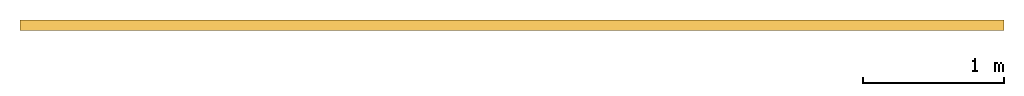
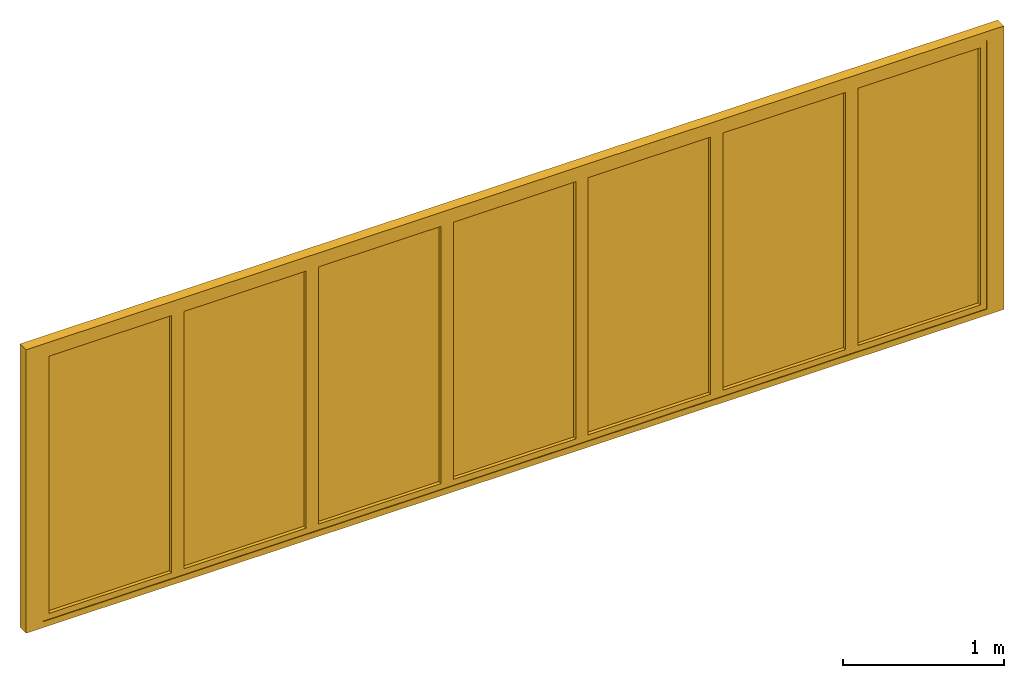
# One storey: 1 door.
"""IFC2X3 building model written with IfcOpenShell, lengths in millimetres."""

from ifc_helpers import new_model, entity, si_unit, converted_unit, direction, frame, frame_2d, origin, origin_2d_with_axis, place, context, subcontext, project, spatial, polyline, rectangle, outline, extrude, source, transform, mapped, material, material_list, type_object, type_shapes, element, save


model = new_model("IFC2X3")

# Units and contexts
model_context = context("Model", 3, precision=1e-06, world=origin(), true_north=direction((2.0, -1.71512652170913e-15, 1.0)))
context_of_model = context(None, 3, precision=1e-06, world=origin(), true_north=direction((2.0, -1.71512652170913e-15, 1.0)))
body_context = subcontext(model_context, "Body", "Model", "MODEL_VIEW")
ifc_project = project(units=[si_unit("LENGTHUNIT", "METRE", prefix="MILLI"), si_unit("AREAUNIT", "SQUARE_METRE", prefix="MILLI"), si_unit("VOLUMEUNIT", "CUBIC_METRE", prefix="MILLI"), converted_unit("PLANEANGLEUNIT", "DEGREE", entity("IfcRatioMeasure", 0.0174532925199433), si_unit("PLANEANGLEUNIT", "RADIAN"), dimensions=[0, 0, 0, 0, 0, 0, 0]), si_unit("TIMEUNIT", "SECOND")], contexts=[model_context, context_of_model])

# Site, building, storey
site_placement = place(None, origin())
site = spatial("IfcSite", under=ifc_project, at=site_placement, CompositionType="ELEMENT")
building_placement = place(site_placement, origin())
building = spatial("IfcBuilding", under=site, at=building_placement, CompositionType="ELEMENT")
storey_placement = place(building_placement, origin())
storey = spatial("IfcBuildingStorey", under=building, at=storey_placement, Name="Ground Floor", CompositionType="ELEMENT", Elevation=0.0)

# Door
ifc_material_1 = material(Name="Glass-Blue")
ifc_material_2 = material(Name="Mtl-Aluminium")
ifc_material_list = material_list([ifc_material_1, ifc_material_2])
door_style = type_object("IfcDoorStyle", ConstructionType="NOTDEFINED", OperationType="NOTDEFINED", ParameterTakesPrecedence=False, Sizeable=False)
shared_shape = source(origin(), body_context, "Body", "SweptSolid", [
    extrude(rectangle(XDim=876.399999999999, YDim=18.0, at=frame_2d((-5.40012479177676e-13, -1.68753899743024e-14), x_axis=(1.0, 0.0))), frame((6845.3148, 265.0, 44.3), z_axis=(0.0, 0.0, 1.0), x_axis=(-1.0, 0.0, 0.0)), (0.0, 0.0, 1.0), 1946.4),
    extrude(outline(polyline([(-482.500000000001, -1017.5), (482.5, -1017.5), (482.5, 1017.5), (-482.500000000001, 1017.5), (-482.500000000001, -1017.5)]), holes=[polyline([(438.199999999999, 973.2), (438.199999999999, -973.2), (-438.2, -973.2), (-438.2, 973.2), (438.199999999999, 973.2)])]), frame((6845.3148, 230.0, 1017.5), z_axis=(0.0, 1.0, 0.0), x_axis=(-1.0, 0.0, 0.0)), (0.0, 0.0, 1.0), 70.0),
    extrude(rectangle(XDim=876.4, YDim=18.0, at=frame_2d((0.0, -1.68753899743024e-14), x_axis=(1.0, 0.0))), frame((5880.3148, 265.0, 44.3), z_axis=(0.0, 0.0, 1.0), x_axis=(-1.0, 0.0, 0.0)), (0.0, 0.0, 1.0), 1946.4),
    extrude(outline(polyline([(-482.5, -1017.5), (482.500000000001, -1017.5), (482.500000000001, 1017.5), (-482.5, 1017.5), (-482.5, -1017.5)]), holes=[polyline([(438.2, 973.2), (438.2, -973.2), (-438.2, -973.2), (-438.2, 973.2), (438.2, 973.2)])]), frame((5880.3148, 230.0, 1017.5), z_axis=(0.0, 1.0, 0.0), x_axis=(-1.0, 0.0, 0.0)), (0.0, 0.0, 1.0), 70.0),
    extrude(rectangle(XDim=876.399999999999, YDim=18.0, at=frame_2d((-2.55795384873636e-13, -1.68753899743024e-14), x_axis=(1.0, 0.0))), frame((4915.3148, 265.0, 44.3), z_axis=(0.0, 0.0, 1.0), x_axis=(-1.0, 0.0, 0.0)), (0.0, 0.0, 1.0), 1946.4),
    extrude(outline(polyline([(-482.5, -1017.5), (482.5, -1017.5), (482.5, 1017.5), (-482.5, 1017.5), (-482.5, -1017.5)]), holes=[polyline([(438.199999999999, 973.2), (438.199999999999, -973.2), (-438.2, -973.2), (-438.2, 973.2), (438.199999999999, 973.2)])]), frame((4915.3148, 230.0, 1017.5), z_axis=(0.0, 1.0, 0.0), x_axis=(-1.0, 0.0, 0.0)), (0.0, 0.0, 1.0), 70.0),
    extrude(rectangle(XDim=876.4, YDim=18.0, at=frame_2d((0.0, -1.68753899743024e-14), x_axis=(1.0, 0.0))), frame((3950.3148, 265.0, 44.3), z_axis=(0.0, 0.0, 1.0), x_axis=(-1.0, 0.0, 0.0)), (0.0, 0.0, 1.0), 1946.4),
    extrude(outline(polyline([(-482.5, -1017.5), (482.5, -1017.5), (482.5, 1017.5), (-482.5, 1017.5), (-482.5, -1017.5)]), holes=[polyline([(438.2, 973.2), (438.2, -973.2), (-438.2, -973.2), (-438.2, 973.2), (438.2, 973.2)])]), frame((3950.3148, 230.0, 1017.5), z_axis=(0.0, 1.0, 0.0), x_axis=(-1.0, 0.0, 0.0)), (0.0, 0.0, 1.0), 70.0),
    extrude(rectangle(XDim=876.399999999999, YDim=18.0, at=frame_2d((2.55795384873636e-13, -1.68753899743024e-14), x_axis=(1.0, 0.0))), frame((2985.3148, 265.0, 44.3), z_axis=(0.0, 0.0, 1.0), x_axis=(-1.0, 0.0, 0.0)), (0.0, 0.0, 1.0), 1946.4),
    extrude(outline(polyline([(-482.5, -1017.5), (482.5, -1017.5), (482.5, 1017.5), (-482.5, 1017.5), (-482.5, -1017.5)]), holes=[polyline([(438.2, 973.2), (438.2, -973.2), (-438.199999999999, -973.2), (-438.199999999999, 973.2), (438.2, 973.2)])]), frame((2985.3148, 230.0, 1017.5), z_axis=(0.0, 1.0, 0.0), x_axis=(-1.0, 0.0, 0.0)), (0.0, 0.0, 1.0), 70.0),
    extrude(rectangle(XDim=876.4, YDim=18.0, at=frame_2d((0.0, -1.68753899743024e-14), x_axis=(1.0, 0.0))), frame((2020.3148, 265.0, 44.3), z_axis=(0.0, 0.0, 1.0), x_axis=(-1.0, 0.0, 0.0)), (0.0, 0.0, 1.0), 1946.4),
    extrude(outline(polyline([(-482.5, -1017.5), (482.5, -1017.5), (482.5, 1017.5), (-482.5, 1017.5), (-482.5, -1017.5)]), holes=[polyline([(438.199999999999, 973.2), (438.199999999999, -973.2), (-438.2, -973.2), (-438.2, 973.2), (438.199999999999, 973.2)])]), frame((2020.3148, 230.0, 1017.5), z_axis=(0.0, 1.0, 0.0), x_axis=(-1.0, 0.0, 0.0)), (0.0, 0.0, 1.0), 70.0),
    extrude(rectangle(XDim=876.4, YDim=18.0, at=frame_2d((5.6843418860808e-14, -1.68753899743024e-14), x_axis=(1.0, 0.0))), frame((1055.3148, 265.0, 44.3), z_axis=(0.0, 0.0, 1.0), x_axis=(-1.0, 0.0, 0.0)), (0.0, 0.0, 1.0), 1946.4),
    extrude(outline(polyline([(-482.5, -1017.5), (482.5, -1017.5), (482.5, 1017.5), (-482.5, 1017.5), (-482.5, -1017.5)]), holes=[polyline([(438.2, 973.2), (438.2, -973.2), (-438.2, -973.2), (-438.2, 973.2), (438.2, 973.2)])]), frame((1055.3148, 230.0, 1017.5), z_axis=(0.0, 1.0, 0.0), x_axis=(-1.0, 0.0, 0.0)), (0.0, 0.0, 1.0), 70.0),
    extrude(rectangle(XDim=122.5, YDim=75.0, at=origin_2d_with_axis()), frame((511.5648, 262.5, 0.0), z_axis=(0.0, 0.0, 1.0), x_axis=(-1.0, 0.0, 0.0)), (0.0, 0.0, 1.0), 2035.0),
    extrude(rectangle(XDim=122.499999999999, YDim=75.0, at=frame_2d((-5.43565192856477e-13, 0.0), x_axis=(1.0, 0.0))), frame((7389.0648, 262.5, 0.0), z_axis=(0.0, 0.0, 1.0), x_axis=(-1.0, 0.0, 0.0)), (0.0, 0.0, 1.0), 2035.0),
    extrude(rectangle(XDim=7000.0, YDim=75.0, at=origin_2d_with_axis()), frame((3950.3148, 262.5, 2035.0), z_axis=(0.0, 0.0, 1.0), x_axis=(-1.0, 0.0, 0.0)), (0.0, 0.0, 1.0), 65.0000000000001),
    extrude(rectangle(XDim=7000.0, YDim=75.0, at=origin_2d_with_axis()), frame((3950.3148, 262.5, -45.0), z_axis=(0.0, 0.0, 1.0), x_axis=(-1.0, 0.0, 0.0)), (0.0, 0.0, 1.0), 45.0),
])
type_shapes(door_style, [shared_shape])
door_placement = place(storey_placement, origin())
element("IfcDoor", 1, at=door_placement, inside=storey, type_object=door_style, material=ifc_material_list, OverallHeight=2145.0, OverallWidth=7000.0, context=body_context, shape_type="MappedRepresentation", body=[
    mapped(shared_shape, transform((0.0, 0.0, 0.0), scale=1.0)),
])

save(model, "model.ifc")
